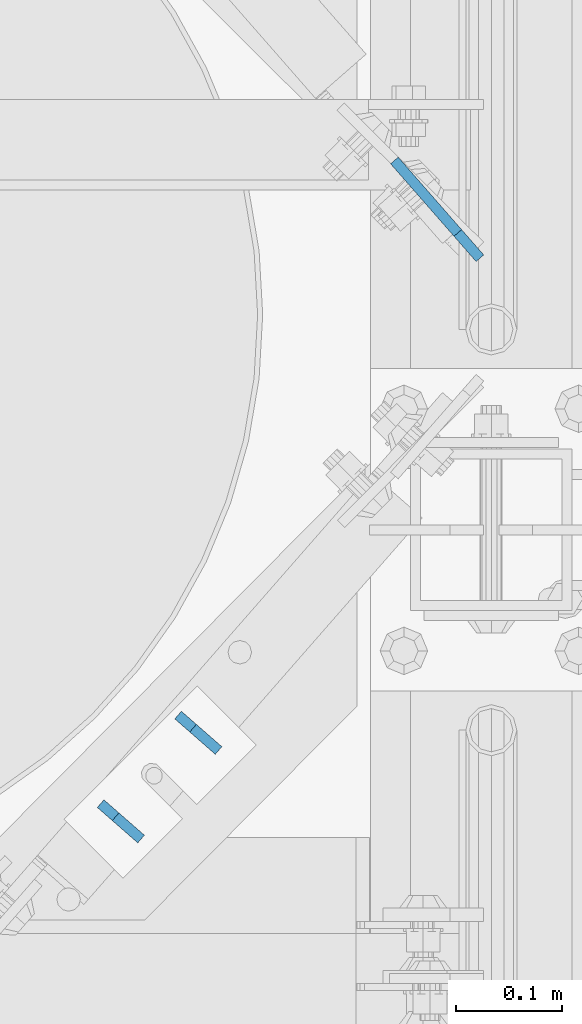
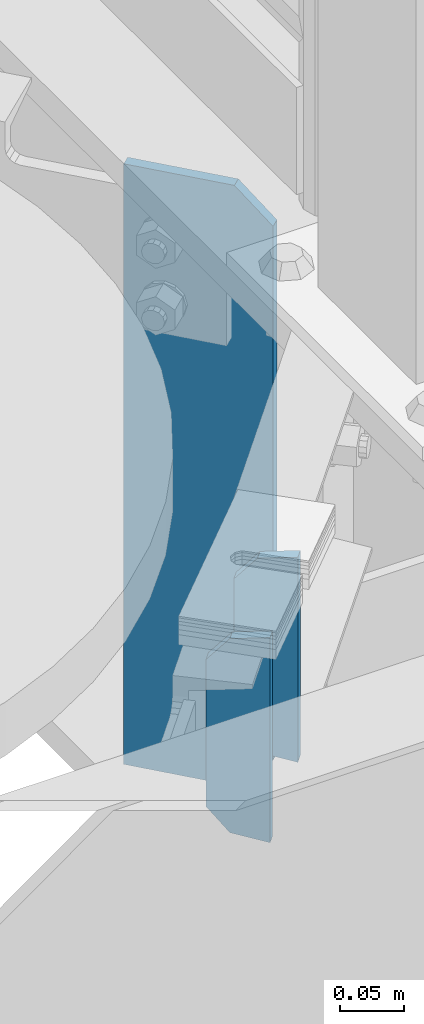
# One storey, part 1651 of 1876: 3 plates, 2 elements without a shape of their own.
"""IFC2X3 building model written with IfcOpenShell, lengths in millimetres."""

from ifc_helpers import new_model, si_unit, frame, origin_with_axes, place, context, subcontext, project, spatial, faceted_brep, material, type_object, element, aggregate, save


model = new_model("IFC2X3")

# Units and contexts
model_context = context("Model", 3, precision=1e-05, world=origin_with_axes())
body_context = subcontext(model_context, "Body", "Model", "MODEL_VIEW")
ifc_project = project(units=[si_unit("LENGTHUNIT", "METRE", prefix="MILLI"), si_unit("AREAUNIT", "SQUARE_METRE"), si_unit("VOLUMEUNIT", "CUBIC_METRE"), si_unit("MASSUNIT", "GRAM", prefix="KILO"), si_unit("TIMEUNIT", "SECOND"), si_unit("PLANEANGLEUNIT", "RADIAN"), si_unit("SOLIDANGLEUNIT", "STERADIAN"), si_unit("THERMODYNAMICTEMPERATUREUNIT", "DEGREE_CELSIUS"), si_unit("LUMINOUSINTENSITYUNIT", "LUMEN")], contexts=[model_context])

# Site, building, storey
site_placement = place(None, origin_with_axes())
site = spatial("IfcSite", under=ifc_project, at=site_placement, CompositionType="ELEMENT")
building_placement = place(site_placement, origin_with_axes())
building = spatial("IfcBuilding", under=site, at=building_placement, Name="Undefined", CompositionType="ELEMENT")
storey_placement = place(building_placement, origin_with_axes())
storey = spatial("IfcBuildingStorey", under=building, at=storey_placement, Name="Undefined", CompositionType="ELEMENT", Elevation=0.0)

# Assembly, plates
assembly_1_placement = place(storey_placement, origin_with_axes())
assembly_1 = element("IfcElementAssembly", 1, at=assembly_1_placement, inside=storey, Name="BEAM", AssemblyPlace="NOTDEFINED", PredefinedType="RIGID_FRAME")
ifc_material = material(Name="STEEL/A36")
plate_type_1 = type_object("IfcPlateType", PredefinedType="NOTDEFINED")
plate_1_placement = place(assembly_1_placement, frame((7362.46499034588, 3347.6167244417, 17784.23545), z_axis=(0.123674694214158, -0.108215357187388, 0.986404585593478), x_axis=(-0.742345102731595, 0.649551964765144, 0.164335003940608)))
plate_1 = element("IfcPlate", 2, at=plate_1_placement, type_object=plate_type_1, material=ifc_material, Name="PLATE", context=body_context, shape_type="Brep", body=[
    faceted_brep([(0.0, -4.76249999999982, 0.0), (32.0008087158794, -4.76249999999982, 192.081680297815), (32.0008087158794, 4.76249999999982, 192.081680297815), (0.0, 4.76249999999982, 0.0), (62.6982748962027, -4.76249999999982, 181.561281061485), (62.6982748962027, 4.76249999999982, 181.561281061485), (77.5887637589458, -4.76249999999982, 156.594231983478), (77.5887637589458, 4.76249999999982, 156.594231983478), (54.6307491805464, -4.76249999999982, 18.791006663906), (54.6307491805464, 4.76249999999982, 18.791006663906), (32.4501686096137, -4.76249999999982, -1.63709046319127e-11), (32.4501686096137, 4.76249999999982, -1.63709046319127e-11)], [[[0, 1, 2, 3]], [[1, 4, 5, 2]], [[4, 6, 7, 5]], [[6, 8, 9, 7]], [[8, 10, 11, 9]], [[10, 0, 3, 11]], [[5, 7, 9, 11, 3, 2]], [[10, 8, 6, 4, 1, 0]]]),
])
plate_2_placement = place(assembly_1_placement, frame((7289.28833655411, 3263.98626294955, 17784.23545), z_axis=(0.123674694214158, -0.108215357187388, 0.986404585593478), x_axis=(-0.742345102731595, 0.649551964765144, 0.164335003940608)))
plate_2 = element("IfcPlate", 3, at=plate_2_placement, type_object=plate_type_1, material=ifc_material, Name="PLATE", context=body_context, shape_type="Brep", body=[
    faceted_brep([(0.0, -4.76249999999982, 0.0), (32.0008087158794, -4.76249999999982, 192.081680297815), (32.0008087158794, 4.76249999999982, 192.081680297815), (0.0, 4.76249999999982, 0.0), (62.6982748962027, -4.76249999999982, 181.561281061485), (62.6982748962027, 4.76249999999982, 181.561281061485), (77.5887637589458, -4.76249999999982, 156.594231983478), (77.5887637589458, 4.76249999999982, 156.594231983478), (54.6307491805464, -4.76249999999982, 18.791006663906), (54.6307491805464, 4.76249999999982, 18.791006663906), (32.4501686096137, -4.76249999999982, -1.63709046319127e-11), (32.4501686096137, 4.76249999999982, -1.63709046319127e-11)], [[[0, 1, 2, 3]], [[1, 4, 5, 2]], [[4, 6, 7, 5]], [[6, 8, 9, 7]], [[8, 10, 11, 9]], [[10, 0, 3, 11]], [[5, 7, 9, 11, 3, 2]], [[10, 8, 6, 4, 1, 0]]]),
])
aggregate(assembly_1, [plate_1, plate_2])

# Assembly, plate
assembly_2_placement = place(storey_placement, origin_with_axes())
assembly_2 = element("IfcElementAssembly", 4, at=assembly_2_placement, inside=storey, Name="BEAM", AssemblyPlace="NOTDEFINED", PredefinedType="RIGID_FRAME")
plate_type_2 = type_object("IfcPlateType", PredefinedType="NOTDEFINED")
plate_3_placement = place(assembly_2_placement, frame((7609.27210406527, 3812.45581269063, 17956.2125), z_axis=(-0.658504607797721, 0.752576694768825, 0.0), x_axis=(0.0, 0.0, -1.0)))
plate_3 = element("IfcPlate", 5, at=plate_3_placement, type_object=plate_type_2, material=ifc_material, Name="PLATE", context=body_context, shape_type="Brep", body=[
    faceted_brep([(-9.76996261670138e-14, -4.76250000000073, 31.75), (0.0, -4.7624999999698, 122.700408935563), (0.0, 4.76250000003165, 122.700408935567), (-9.76996261670138e-14, 4.76250000000073, 31.75), (569.912475585938, -4.7624999999698, 122.700408935563), (569.912475585938, 4.76250000003165, 122.700408935567), (569.912475585938, -4.76249999999345, 31.7500000000023), (569.912475585938, 4.762500000008, 31.7500000000055), (538.162475585938, -4.76250000000073, -3.18323145620525e-12), (538.162475585938, 4.76250000000073, 4.54747350886464e-13), (31.75, -4.76250000000073, 0.0), (31.75, 4.76250000000073, 0.0)], [[[0, 1, 2, 3]], [[1, 4, 5, 2]], [[4, 6, 7, 5]], [[6, 8, 9, 7]], [[8, 10, 11, 9]], [[10, 0, 3, 11]], [[5, 7, 9, 11, 3, 2]], [[10, 8, 6, 4, 1, 0]]]),
])
aggregate(assembly_2, [plate_3])

save(model, "model.ifc")
